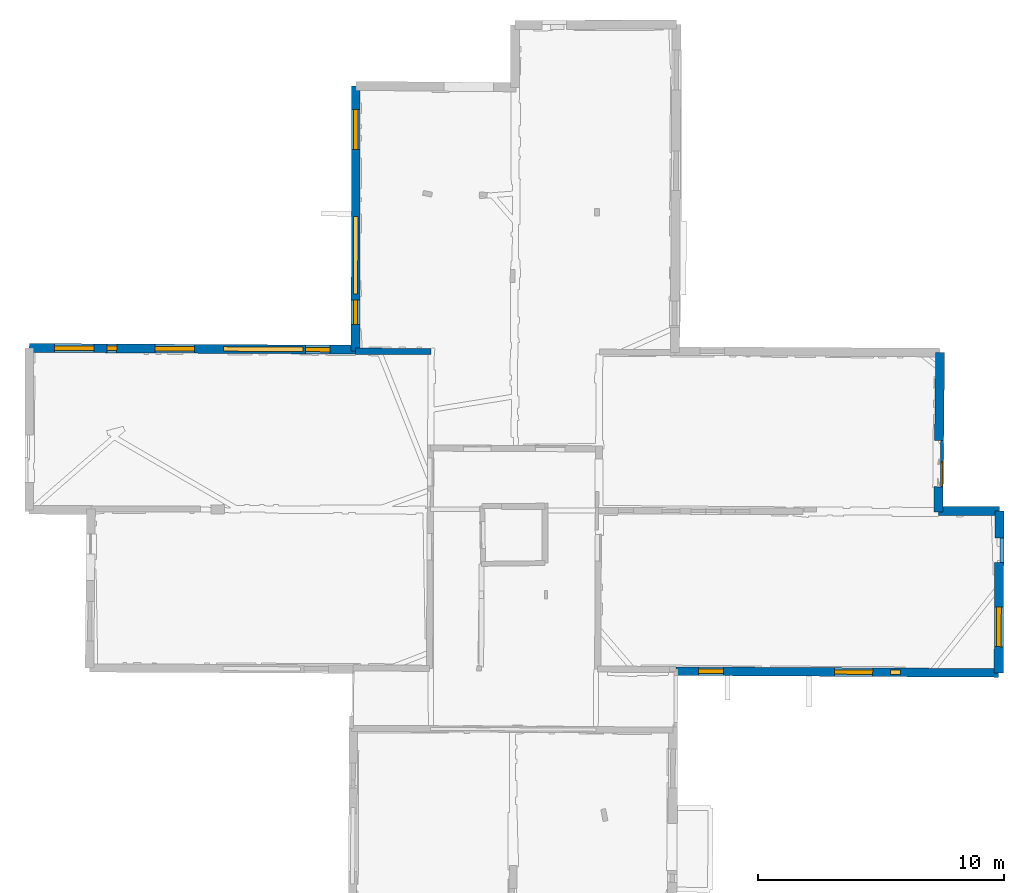
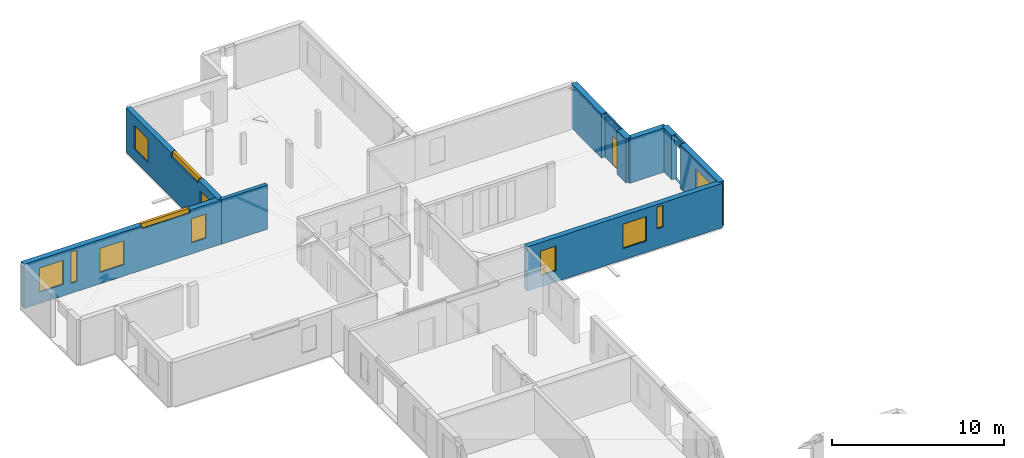
# One storey, part 8 of 14: 13 windows, 11 walls, 14 openings.
"""IFC2X3 building model written with IfcOpenShell, lengths in metres."""

from ifc_helpers import new_model, entity, si_unit, converted_unit, derived_unit, direction, frame, frame_2d, origin, origin_2d_with_axis, place, context, subcontext, project, spatial, polyline, rectangle, outline, extrude, source, transform, mapped, material, layer, layer_set, layer_usage, type_object, type_shapes, element, fill, save


model = new_model("IFC2X3")

# Units and contexts
model_context = context("Model", 3, precision=1e-05, world=origin(), true_north=direction((0.0, 1.0)))
body_context = subcontext(model_context, "Body", "Model", "MODEL_VIEW")
ifc_project = project(units=[si_unit("LENGTHUNIT", "METRE"), si_unit("AREAUNIT", "SQUARE_METRE"), si_unit("VOLUMEUNIT", "CUBIC_METRE"), converted_unit("PLANEANGLEUNIT", "DEGREE", entity("IfcRatioMeasure", 0.0174532925199433), si_unit("PLANEANGLEUNIT", "RADIAN"), dimensions=[0, 0, 0, 0, 0, 0, 0]), si_unit("MASSUNIT", "GRAM", prefix="KILO"), derived_unit("MASSDENSITYUNIT", [(si_unit("MASSUNIT", "GRAM", prefix="KILO"), 1), (si_unit("LENGTHUNIT", "METRE"), -3)]), derived_unit("MOMENTOFINERTIAUNIT", [(si_unit("LENGTHUNIT", "METRE"), 4)]), si_unit("TIMEUNIT", "SECOND"), si_unit("FREQUENCYUNIT", "HERTZ"), si_unit("THERMODYNAMICTEMPERATUREUNIT", "DEGREE_CELSIUS"), derived_unit("THERMALTRANSMITTANCEUNIT", [(si_unit("MASSUNIT", "GRAM", prefix="KILO"), 1), (si_unit("THERMODYNAMICTEMPERATUREUNIT", "KELVIN"), -1), (si_unit("TIMEUNIT", "SECOND"), -3)]), derived_unit("VOLUMETRICFLOWRATEUNIT", [(si_unit("LENGTHUNIT", "METRE"), 3), (si_unit("TIMEUNIT", "SECOND"), -1)]), si_unit("ELECTRICCURRENTUNIT", "AMPERE"), si_unit("ELECTRICVOLTAGEUNIT", "VOLT"), si_unit("POWERUNIT", "WATT"), si_unit("FORCEUNIT", "NEWTON", prefix="KILO"), si_unit("ILLUMINANCEUNIT", "LUX"), si_unit("LUMINOUSFLUXUNIT", "LUMEN"), si_unit("LUMINOUSINTENSITYUNIT", "CANDELA"), derived_unit("USERDEFINED", [(si_unit("MASSUNIT", "GRAM", prefix="KILO"), -1), (si_unit("LENGTHUNIT", "METRE"), -2), (si_unit("TIMEUNIT", "SECOND"), 3), (si_unit("LUMINOUSFLUXUNIT", "LUMEN"), 1)]), derived_unit("LINEARVELOCITYUNIT", [(si_unit("LENGTHUNIT", "METRE"), 1), (si_unit("TIMEUNIT", "SECOND"), -1)]), si_unit("PRESSUREUNIT", "PASCAL"), derived_unit("USERDEFINED", [(si_unit("LENGTHUNIT", "METRE"), -2), (si_unit("MASSUNIT", "GRAM", prefix="KILO"), 1), (si_unit("TIMEUNIT", "SECOND"), -2)]), derived_unit("LINEARFORCEUNIT", [(si_unit("MASSUNIT", "GRAM", prefix="KILO"), 1), (si_unit("LENGTHUNIT", "METRE"), 1), (si_unit("TIMEUNIT", "SECOND"), -2), (si_unit("LENGTHUNIT", "METRE"), -1)]), derived_unit("PLANARFORCEUNIT", [(si_unit("MASSUNIT", "GRAM", prefix="KILO"), 1), (si_unit("LENGTHUNIT", "METRE"), 1), (si_unit("TIMEUNIT", "SECOND"), -2), (si_unit("LENGTHUNIT", "METRE"), -2)])], contexts=[model_context])

# Site, building, storey
placement = place(None, origin())
site = spatial("IfcSite", under=ifc_project, at=placement, CompositionType="ELEMENT")
building = spatial("IfcBuilding", under=site, at=placement, CompositionType="ELEMENT")
storey_placement = place(placement, frame((0.0, 0.0, 8.83152770996094)))
storey = spatial("IfcBuildingStorey", under=building, at=storey_placement, Name="Level 4", CompositionType="ELEMENT", Elevation=8.83152770996094)

# Wall
ifc_material_1 = material(Name="Default wall")
ifc_layer_1 = layer(ifc_material_1, 0.25)
ifc_layer_set_1 = layer_set([ifc_layer_1], Name="wall_thickness_0.2500")
ifc_layer_usage_1 = layer_usage(ifc_layer_set_1, "AXIS2", "POSITIVE", -0.125)
wall_type_1 = type_object("IfcWallType", Name="wall_thickness_0.2500", PredefinedType="STANDARD", material=ifc_layer_set_1)
wall_1_placement = place(storey_placement, frame((-0.0725966707851251, 64.0874716307133, 0.0), z_axis=(0.0, 0.0, 1.0), x_axis=(0.999995007272062, -0.00315997325119514, 0.0)))
element("IfcWallStandardCase", 1, at=wall_1_placement, inside=storey, type_object=wall_type_1, material=ifc_layer_usage_1, Name="Wall:471", ObjectType="Wall", context=body_context, shape_type="SweptSolid", body=[
    extrude(outline(polyline([(3.07351311743161, -0.125), (3.07351311743161, 0.125), (0.0, 0.125), (0.0, -0.125), (3.07351311743161, -0.125)])), origin(), (0.0, 0.0, 1.0), 3.14668312072754),
])

# Wall, openings, windows
ifc_layer_2 = layer(ifc_material_1, 0.349999994039536)
ifc_layer_set_2 = layer_set([ifc_layer_2], Name="wall_thickness_0.3500")
ifc_layer_usage_2 = layer_usage(ifc_layer_set_2, "AXIS2", "POSITIVE", -0.174999997019768)
wall_type_2 = type_object("IfcWallType", Name="wall_thickness_0.3500", PredefinedType="STANDARD", material=ifc_layer_set_2)
wall_2_placement = place(storey_placement, frame((12.9328662606989, 51.1108377214405, 0.0), z_axis=(0.0, 0.0, 1.0), x_axis=(0.999983532806537, -0.00573882529414689, 0.0)))
wall_2 = element("IfcWallStandardCase", 2, at=wall_2_placement, inside=storey, type_object=wall_type_2, material=ifc_layer_usage_2, Name="Wall:474", ObjectType="Wall", context=body_context, shape_type="SweptSolid", body=[
    extrude(outline(polyline([(13.0916100065132, -0.174999997019768), (13.0916100065132, 0.174999997019768), (0.0, 0.174999997019768), (0.0, -0.174999997019768), (13.0916100065132, -0.174999997019768)])), origin(), (0.0, 0.0, 1.0), 3.14668312072754),
])
opening_1_placement = place(wall_2_placement, frame((8.6957989304469, -0.174999997019768, 1.41847229003906)))
opening_1 = element("IfcOpeningElement", 3, at=opening_1_placement, cuts=wall_2, Name="Opening : 415 x 1540 : 368", ObjectType="Opening", context=body_context, shape_type="SweptSolid", body=[
    extrude(rectangle(XDim=0.415, YDim=1.54, at=frame_2d((0.77, 0.2075), x_axis=(0.0, 1.0))), frame((0.0, 0.0, 0.0), z_axis=(0.0, 1.0, 0.0), x_axis=(0.0, 0.0, 1.0)), (0.0, 0.0, 1.0), 0.349999994039536),
])
opening_2_placement = place(wall_2_placement, frame((0.911729487264428, -0.174999997019768, 0.800472259521484)))
opening_2 = element("IfcOpeningElement", 4, at=opening_2_placement, cuts=wall_2, Name="Opening : 1010 x 1745 : 369", ObjectType="Opening", context=body_context, shape_type="SweptSolid", body=[
    extrude(rectangle(XDim=1.01, YDim=1.745, at=frame_2d((0.8725, 0.505), x_axis=(0.0, 1.0))), frame((0.0, 0.0, 0.0), z_axis=(0.0, 1.0, 0.0), x_axis=(0.0, 0.0, 1.0)), (0.0, 0.0, 1.0), 0.349999994039536),
])
opening_3_placement = place(wall_2_placement, frame((6.4217307997999, -0.174999997019768, 0.805472373962402)))
opening_3 = element("IfcOpeningElement", 5, at=opening_3_placement, cuts=wall_2, Name="Opening : 1560 x 1740 : 370", ObjectType="Opening", context=body_context, shape_type="SweptSolid", body=[
    extrude(rectangle(XDim=1.56, YDim=1.74, at=frame_2d((0.87, 0.78), x_axis=(0.0, 1.0))), frame((0.0, 0.0, 0.0), z_axis=(0.0, 1.0, 0.0), x_axis=(0.0, 0.0, 1.0)), (0.0, 0.0, 1.0), 0.349999994039536),
])
ifc_material_2 = material(Name="Window Default")
window_style_1 = type_object("IfcWindowStyle", Name="Window : 415 x 1540mm", ConstructionType="NOTDEFINED", OperationType="NOTDEFINED", ParameterTakesPrecedence=False, Sizeable=False, material=ifc_material_2)
shared_shape_1 = source(origin(), body_context, "Body", "SweptSolid", [
    extrude(rectangle(XDim=0.174999997019768, YDim=0.415, at=origin_2d_with_axis()), frame((0.2075, 0.174999997019768, 0.0), z_axis=(0.0, 0.0, 1.0), x_axis=(0.0, 1.0, 0.0)), (0.0, 0.0, 1.0), 1.54),
])
type_shapes(window_style_1, [shared_shape_1])
window_1_placement = place(opening_1_placement, origin())
window_1 = element("IfcWindow", 6, at=window_1_placement, inside=storey, type_object=window_style_1, Name="Window : 415 x 1540mm : 200", ObjectType="Window : 415 x 1540mm", OverallHeight=1.54, OverallWidth=0.415, context=body_context, shape_type="MappedRepresentation", body=[
    mapped(shared_shape_1, transform((0.0, 0.0, 0.0), scale=1.0)),
])
fill(opening_1, window_1)
window_style_2 = type_object("IfcWindowStyle", Name="Window : 1010 x 1745mm", ConstructionType="NOTDEFINED", OperationType="NOTDEFINED", ParameterTakesPrecedence=False, Sizeable=False, material=ifc_material_2)
shared_shape_2 = source(origin(), body_context, "Body", "SweptSolid", [
    extrude(rectangle(XDim=0.174999997019768, YDim=1.01, at=origin_2d_with_axis()), frame((0.505, 0.174999997019768, 0.0), z_axis=(0.0, 0.0, 1.0), x_axis=(0.0, 1.0, 0.0)), (0.0, 0.0, 1.0), 1.745),
])
type_shapes(window_style_2, [shared_shape_2])
window_2_placement = place(opening_2_placement, origin())
window_2 = element("IfcWindow", 7, at=window_2_placement, inside=storey, type_object=window_style_2, Name="Window : 1010 x 1745mm : 201", ObjectType="Window : 1010 x 1745mm", OverallHeight=1.745, OverallWidth=1.01, context=body_context, shape_type="MappedRepresentation", body=[
    mapped(shared_shape_2, transform((0.0, 0.0, 0.0), scale=1.0)),
])
fill(opening_2, window_2)
window_style_3 = type_object("IfcWindowStyle", Name="Window : 1560 x 1740mm", ConstructionType="NOTDEFINED", OperationType="NOTDEFINED", ParameterTakesPrecedence=False, Sizeable=False, material=ifc_material_2)
shared_shape_3 = source(origin(), body_context, "Body", "SweptSolid", [
    extrude(rectangle(XDim=0.174999997019768, YDim=1.56, at=origin_2d_with_axis()), frame((0.78, 0.174999997019768, 0.0), z_axis=(0.0, 0.0, 1.0), x_axis=(0.0, 1.0, 0.0)), (0.0, 0.0, 1.0), 1.74),
])
type_shapes(window_style_3, [shared_shape_3])
window_3_placement = place(opening_3_placement, origin())
window_3 = element("IfcWindow", 8, at=window_3_placement, inside=storey, type_object=window_style_3, Name="Window : 1560 x 1740mm : 202", ObjectType="Window : 1560 x 1740mm", OverallHeight=1.74, OverallWidth=1.56, context=body_context, shape_type="MappedRepresentation", body=[
    mapped(shared_shape_3, transform((0.0, 0.0, 0.0), scale=1.0)),
])
fill(opening_3, window_3)

wall_3_placement = place(storey_placement, frame((-0.0536861734466659, 74.854894371162, 0.0), z_axis=(0.0, 0.0, 1.0), x_axis=(-0.00175628624668275, -0.99999845772812, 0.0)))
wall_3 = element("IfcWallStandardCase", 9, at=wall_3_placement, inside=storey, type_object=wall_type_2, material=ifc_layer_usage_2, Name="Wall:477", ObjectType="Wall", context=body_context, shape_type="SweptSolid", body=[
    extrude(outline(polyline([(10.7674650316515, -0.174999997019768), (10.7674650316515, 0.174999997019768), (0.0, 0.174999997019768), (0.0, -0.174999997019768), (10.7674650316515, -0.174999997019768)])), origin(), (0.0, 0.0, 1.0), 3.14668312072754),
])
opening_4_placement = place(wall_3_placement, frame((5.29773766272082, -0.174999997019768, 2.88547229766846)))
opening_4 = element("IfcOpeningElement", 10, at=opening_4_placement, cuts=wall_3, Name="Opening : 3145 x 355 : 371", ObjectType="Opening", context=body_context, shape_type="SweptSolid", body=[
    extrude(rectangle(XDim=3.145, YDim=0.355, at=frame_2d((0.1775, 1.5725), x_axis=(0.0, 1.0))), frame((0.0, 0.0, 0.0), z_axis=(0.0, 1.0, 0.0), x_axis=(0.0, 0.0, 1.0)), (0.0, 0.0, 1.0), 0.349999994039536),
])
opening_5_placement = place(wall_3_placement, frame((0.960702470474783, -0.174999997019768, 0.800472259521484)))
opening_5 = element("IfcOpeningElement", 11, at=opening_5_placement, cuts=wall_3, Name="Opening : 1615 x 1700 : 372", ObjectType="Opening", context=body_context, shape_type="SweptSolid", body=[
    extrude(rectangle(XDim=1.615, YDim=1.7, at=frame_2d((0.85, 0.8075), x_axis=(0.0, 1.0))), frame((0.0, 0.0, 0.0), z_axis=(0.0, 1.0, 0.0), x_axis=(0.0, 0.0, 1.0)), (0.0, 0.0, 1.0), 0.349999994039536),
])
opening_6_placement = place(wall_3_placement, frame((8.68570522925139, -0.174999997019768, 0.800472259521484)))
opening_6 = element("IfcOpeningElement", 12, at=opening_6_placement, cuts=wall_3, Name="Opening : 1000 x 1715 : 373", ObjectType="Opening", context=body_context, shape_type="SweptSolid", body=[
    extrude(rectangle(XDim=1.0, YDim=1.715, at=frame_2d((0.8575, 0.5), x_axis=(0.0, 1.0))), frame((0.0, 0.0, 0.0), z_axis=(0.0, 1.0, 0.0), x_axis=(0.0, 0.0, 1.0)), (0.0, 0.0, 1.0), 0.349999994039536),
])
window_style_4 = type_object("IfcWindowStyle", Name="Window : 3145 x 355mm", ConstructionType="NOTDEFINED", OperationType="NOTDEFINED", ParameterTakesPrecedence=False, Sizeable=False, material=ifc_material_2)
shared_shape_4 = source(origin(), body_context, "Body", "SweptSolid", [
    extrude(rectangle(XDim=0.174999997019768, YDim=3.145, at=origin_2d_with_axis()), frame((1.5725, 0.174999997019768, 0.0), z_axis=(0.0, 0.0, 1.0), x_axis=(0.0, 1.0, 0.0)), (0.0, 0.0, 1.0), 0.355),
])
type_shapes(window_style_4, [shared_shape_4])
window_4_placement = place(opening_4_placement, origin())
window_4 = element("IfcWindow", 13, at=window_4_placement, inside=storey, type_object=window_style_4, Name="Window : 3145 x 355mm : 203", ObjectType="Window : 3145 x 355mm", OverallHeight=0.355, OverallWidth=3.145, context=body_context, shape_type="MappedRepresentation", body=[
    mapped(shared_shape_4, transform((0.0, 0.0, 0.0), scale=1.0)),
])
fill(opening_4, window_4)
window_style_5 = type_object("IfcWindowStyle", Name="Window : 1615 x 1700mm", ConstructionType="NOTDEFINED", OperationType="NOTDEFINED", ParameterTakesPrecedence=False, Sizeable=False, material=ifc_material_2)
shared_shape_5 = source(origin(), body_context, "Body", "SweptSolid", [
    extrude(rectangle(XDim=0.174999997019768, YDim=1.615, at=origin_2d_with_axis()), frame((0.8075, 0.174999997019768, 0.0), z_axis=(0.0, 0.0, 1.0), x_axis=(0.0, 1.0, 0.0)), (0.0, 0.0, 1.0), 1.7),
])
type_shapes(window_style_5, [shared_shape_5])
window_5_placement = place(opening_5_placement, origin())
window_5 = element("IfcWindow", 14, at=window_5_placement, inside=storey, type_object=window_style_5, Name="Window : 1615 x 1700mm : 204", ObjectType="Window : 1615 x 1700mm", OverallHeight=1.7, OverallWidth=1.615, context=body_context, shape_type="MappedRepresentation", body=[
    mapped(shared_shape_5, transform((0.0, 0.0, 0.0), scale=1.0)),
])
fill(opening_5, window_5)
window_style_6 = type_object("IfcWindowStyle", Name="Window : 1000 x 1715mm", ConstructionType="NOTDEFINED", OperationType="NOTDEFINED", ParameterTakesPrecedence=False, Sizeable=False, material=ifc_material_2)
shared_shape_6 = source(origin(), body_context, "Body", "SweptSolid", [
    extrude(rectangle(XDim=0.174999997019768, YDim=1.0, at=origin_2d_with_axis()), frame((0.5, 0.174999997019768, 0.0), z_axis=(0.0, 0.0, 1.0), x_axis=(0.0, 1.0, 0.0)), (0.0, 0.0, 1.0), 1.715),
])
type_shapes(window_style_6, [shared_shape_6])
window_6_placement = place(opening_6_placement, origin())
window_6 = element("IfcWindow", 15, at=window_6_placement, inside=storey, type_object=window_style_6, Name="Window : 1000 x 1715mm : 205", ObjectType="Window : 1000 x 1715mm", OverallHeight=1.715, OverallWidth=1.0, context=body_context, shape_type="MappedRepresentation", body=[
    mapped(shared_shape_6, transform((0.0, 0.0, 0.0), scale=1.0)),
])
fill(opening_6, window_6)

# Wall, opening, window
ifc_layer_3 = layer(ifc_material_1, 0.119999997317791)
ifc_layer_set_3 = layer_set([ifc_layer_3], Name="wall_thickness_0.1200")
ifc_layer_usage_3 = layer_usage(ifc_layer_set_3, "AXIS2", "POSITIVE", -0.0599999986588955)
wall_type_3 = type_object("IfcWallType", Name="wall_thickness_0.1200", PredefinedType="STANDARD", material=ifc_layer_set_3)
wall_4_placement = place(storey_placement, frame((23.7334984998633, 60.4629093633367, 0.0), z_axis=(0.0, 0.0, 1.0), x_axis=(-0.0107502948328972, -0.999942213910887, 0.0)))
wall_4 = element("IfcWallStandardCase", 16, at=wall_4_placement, inside=storey, type_object=wall_type_3, material=ifc_layer_usage_3, Name="Wall:486", ObjectType="Wall", context=body_context, shape_type="SweptSolid", body=[
    extrude(outline(polyline([(1.87500535240021, -0.0599999986588955), (1.87500535240021, 0.0599999986588955), (0.0, 0.0599999986588955), (0.0, -0.0599999986588955), (1.87500535240021, -0.0599999986588955)])), origin(), (0.0, 0.0, 1.0), 3.14668312072754),
])
opening_7_placement = place(wall_4_placement, frame((0.849967488055786, -0.0599999986588955, 0.0354728698730469)))
opening_7 = element("IfcOpeningElement", 17, at=opening_7_placement, cuts=wall_4, Name="Opening : 1020 x 1985 : 378", ObjectType="Opening", context=body_context, shape_type="SweptSolid", body=[
    extrude(rectangle(XDim=1.02, YDim=1.985, at=frame_2d((0.9925, 0.51), x_axis=(0.0, 1.0))), frame((0.0, 0.0, 0.0), z_axis=(0.0, 1.0, 0.0), x_axis=(0.0, 0.0, 1.0)), (0.0, 0.0, 1.0), 0.119999997317791),
])
window_style_7 = type_object("IfcWindowStyle", Name="Window : 1020 x 1985mm", ConstructionType="NOTDEFINED", OperationType="NOTDEFINED", ParameterTakesPrecedence=False, Sizeable=False, material=ifc_material_2)
shared_shape_7 = source(origin(), body_context, "Body", "SweptSolid", [
    extrude(rectangle(XDim=0.0599999986588955, YDim=1.02, at=origin_2d_with_axis()), frame((0.51, 0.0599999986588955, 0.0), z_axis=(0.0, 0.0, 1.0), x_axis=(0.0, 1.0, 0.0)), (0.0, 0.0, 1.0), 1.985),
])
type_shapes(window_style_7, [shared_shape_7])
window_7_placement = place(opening_7_placement, origin())
window_7 = element("IfcWindow", 18, at=window_7_placement, inside=storey, type_object=window_style_7, Name="Window : 1020 x 1985mm : 206", ObjectType="Window : 1020 x 1985mm", OverallHeight=1.985, OverallWidth=1.02, context=body_context, shape_type="MappedRepresentation", body=[
    mapped(shared_shape_7, transform((0.0, 0.0, 0.0), scale=1.0)),
])
fill(opening_7, window_7)

# Wall
ifc_layer_4 = layer(ifc_material_1, 0.370000004768372)
ifc_layer_set_4 = layer_set([ifc_layer_4], Name="wall_thickness_0.3700")
ifc_layer_usage_4 = layer_usage(ifc_layer_set_4, "AXIS2", "POSITIVE", -0.185000002384186)
wall_type_4 = type_object("IfcWallType", Name="wall_thickness_0.3700", PredefinedType="STANDARD", material=ifc_layer_set_4)
wall_5_placement = place(storey_placement, frame((26.0541624507356, 57.607519848895, 0.0), z_axis=(0.0, 0.0, 1.0), x_axis=(-0.00454995237997201, -0.999989648913097, 0.0)))
element("IfcWallStandardCase", 19, at=wall_5_placement, inside=storey, type_object=wall_type_4, material=ifc_layer_usage_4, Name="Wall:401", ObjectType="Wall", context=body_context, shape_type="SweptSolid", body=[
    extrude(outline(polyline([(1.09495533422196, -0.185000002384186), (1.09495533422196, 0.185000002384186), (0.0, 0.185000002384186), (0.0, -0.185000002384186), (1.09495533422196, -0.185000002384186)])), origin(), (0.0, 0.0, 1.0), 3.14668312072754),
])

# Wall, opening, window
wall_6_placement = place(storey_placement, frame((26.0446257065105, 55.5126023183358, 0.0), z_axis=(0.0, 0.0, 1.0), x_axis=(-0.00454923798231252, -0.999989652163351, 0.0)))
wall_6 = element("IfcWallStandardCase", 20, at=wall_6_placement, inside=storey, type_object=wall_type_4, material=ifc_layer_usage_4, Name="Wall:402", ObjectType="Wall", context=body_context, shape_type="SweptSolid", body=[
    extrude(outline(polyline([(4.47694070531321, -0.185000002384186), (4.47694070531321, 0.185000002384186), (0.0, 0.185000002384186), (0.0, -0.185000002384186), (4.47694070531321, -0.185000002384186)])), origin(), (0.0, 0.0, 1.0), 3.14668312072754),
])
opening_8_placement = place(wall_6_placement, frame((1.80821573201221, -0.185000002384186, 0.805472373962402)))
opening_8 = element("IfcOpeningElement", 21, at=opening_8_placement, cuts=wall_6, Name="Opening : 1605 x 1695 : 323", ObjectType="Opening", context=body_context, shape_type="SweptSolid", body=[
    extrude(rectangle(XDim=1.605, YDim=1.695, at=frame_2d((0.8475, 0.8025), x_axis=(0.0, 1.0))), frame((0.0, 0.0, 0.0), z_axis=(0.0, 1.0, 0.0), x_axis=(0.0, 0.0, 1.0)), (0.0, 0.0, 1.0), 0.370000004768372),
])
window_style_8 = type_object("IfcWindowStyle", Name="Window : 1605 x 1695mm", ConstructionType="NOTDEFINED", OperationType="NOTDEFINED", ParameterTakesPrecedence=False, Sizeable=False, material=ifc_material_2)
shared_shape_8 = source(origin(), body_context, "Body", "SweptSolid", [
    extrude(rectangle(XDim=0.185000002384186, YDim=1.605, at=origin_2d_with_axis()), frame((0.8025, 0.185000002384186, 0.0), z_axis=(0.0, 0.0, 1.0), x_axis=(0.0, 1.0, 0.0)), (0.0, 0.0, 1.0), 1.695),
])
type_shapes(window_style_8, [shared_shape_8])
window_8_placement = place(opening_8_placement, origin())
window_8 = element("IfcWindow", 22, at=window_8_placement, inside=storey, type_object=window_style_8, Name="Window : 1605 x 1695mm : 174", ObjectType="Window : 1605 x 1695mm", OverallHeight=1.695, OverallWidth=1.605, context=body_context, shape_type="MappedRepresentation", body=[
    mapped(shared_shape_8, transform((0.0, 0.0, 0.0), scale=1.0)),
])
fill(opening_8, window_8)

# Walls
wall_7_placement = place(storey_placement, frame((23.6468136752284, 64.0337838540516, 0.0), z_axis=(0.0, 0.0, 1.0), x_axis=(-0.0110572017912558, -0.999938867275669, 0.0)))
element("IfcWallStandardCase", 23, at=wall_7_placement, inside=storey, type_object=wall_type_4, material=ifc_layer_usage_4, Name="Wall:408", ObjectType="Wall", context=body_context, shape_type="SweptSolid", body=[
    extrude(outline(polyline([(3.56968004677602, -0.185000002384186), (3.56968004677602, 0.185000002384186), (0.0, 0.185000002384186), (0.0, -0.185000002384186), (3.56968004677602, -0.185000002384186)])), origin(), (0.0, 0.0, 1.0), 3.14668312072754),
])
wall_8_placement = place(storey_placement, frame((23.5866101250468, 58.5894328444568, 0.0), z_axis=(0.0, 0.0, 1.0), x_axis=(-0.0110569858478835, -0.999938869663521, 0.0)))
element("IfcWallStandardCase", 24, at=wall_8_placement, inside=storey, type_object=wall_type_4, material=ifc_layer_usage_4, Name="Wall:409", ObjectType="Wall", context=body_context, shape_type="SweptSolid", body=[
    extrude(outline(polyline([(1.02224495477766, -0.185000002384186), (1.02224495477766, 0.185000002384186), (0.0, 0.185000002384186), (0.0, -0.185000002384186), (1.02224495477766, -0.185000002384186)])), origin(), (0.0, 0.0, 1.0), 3.14668312072754),
])
ifc_layer_5 = layer(ifc_material_1, 0.360000014305115)
ifc_layer_set_5 = layer_set([ifc_layer_5], Name="wall_thickness_0.3600")
ifc_layer_usage_5 = layer_usage(ifc_layer_set_5, "AXIS2", "POSITIVE", -0.180000007152557)
wall_type_5 = type_object("IfcWallType", Name="wall_thickness_0.3600", PredefinedType="STANDARD", material=ifc_layer_set_5)
wall_9_placement = place(storey_placement, frame((23.575710408771, 57.6039166560691, 0.0), z_axis=(0.0, 0.0, 1.0), x_axis=(0.999998942225334, 0.00145449242455361, 0.0)))
element("IfcWallStandardCase", 25, at=wall_9_placement, inside=storey, type_object=wall_type_5, material=ifc_layer_usage_5, Name="Wall:497", ObjectType="Wall", context=body_context, shape_type="SweptSolid", body=[
    extrude(outline(polyline([(2.47845148944105, -0.180000007152557), (2.47845148944105, 0.180000007152557), (0.0, 0.180000007152557), (0.0, -0.180000007152557), (2.47845148944105, -0.180000007152557)])), origin(), (0.0, 0.0, 1.0), 3.14668312072754),
])

# Wall, openings, windows
wall_10_placement = place(storey_placement, frame((-13.305897288311, 64.2230024712479, 0.0), z_axis=(0.0, 0.0, 1.0), x_axis=(0.999985552208707, -0.00537544173512645, 0.0)))
wall_10 = element("IfcWallStandardCase", 26, at=wall_10_placement, inside=storey, type_object=wall_type_5, material=ifc_layer_usage_5, Name="Wall:502", ObjectType="Wall", context=body_context, shape_type="SweptSolid", body=[
    extrude(outline(polyline([(13.2336053694947, -0.180000007152557), (13.2336053694947, 0.180000007152557), (0.0, 0.180000007152557), (0.0, -0.180000007152557), (13.2336053694947, -0.180000007152557)])), origin(), (0.0, 0.0, 1.0), 3.14668312072754),
])
opening_9_placement = place(wall_10_placement, frame((3.14552846936702, -0.180000007152557, 0.699471473693848)))
opening_9 = element("IfcOpeningElement", 27, at=opening_9_placement, cuts=wall_10, Name="Opening : 405 x 2235 : 397", ObjectType="Opening", context=body_context, shape_type="SweptSolid", body=[
    extrude(rectangle(XDim=0.405, YDim=2.235, at=frame_2d((1.1175, 0.2025), x_axis=(0.0, 1.0))), frame((0.0, 0.0, 0.0), z_axis=(0.0, 1.0, 0.0), x_axis=(0.0, 0.0, 1.0)), (0.0, 0.0, 1.0), 0.360000014305115),
])
opening_10_placement = place(wall_10_placement, frame((1.03242267636601, -0.180000007152557, 0.81047248840332)))
opening_10 = element("IfcOpeningElement", 28, at=opening_10_placement, cuts=wall_10, Name="Opening : 1595 x 1720 : 398", ObjectType="Opening", context=body_context, shape_type="SweptSolid", body=[
    extrude(rectangle(XDim=1.595, YDim=1.72, at=frame_2d((0.86, 0.7975), x_axis=(0.0, 1.0))), frame((0.0, 0.0, 0.0), z_axis=(0.0, 1.0, 0.0), x_axis=(0.0, 0.0, 1.0)), (0.0, 0.0, 1.0), 0.360000014305115),
])
opening_11_placement = place(wall_10_placement, frame((5.10242392863749, -0.180000007152557, 0.800472259521484)))
opening_11 = element("IfcOpeningElement", 29, at=opening_11_placement, cuts=wall_10, Name="Opening : 1605 x 1715 : 399", ObjectType="Opening", context=body_context, shape_type="SweptSolid", body=[
    extrude(rectangle(XDim=1.605, YDim=1.715, at=frame_2d((0.8575, 0.8025), x_axis=(0.0, 1.0))), frame((0.0, 0.0, 0.0), z_axis=(0.0, 1.0, 0.0), x_axis=(0.0, 0.0, 1.0)), (0.0, 0.0, 1.0), 0.360000014305115),
])
opening_12_placement = place(wall_10_placement, frame((7.88742347267984, -0.180000007152557, 2.92547225952148)))
opening_12 = element("IfcOpeningElement", 30, at=opening_12_placement, cuts=wall_10, Name="Opening : 3215 x 315 : 400", ObjectType="Opening", context=body_context, shape_type="SweptSolid", body=[
    extrude(rectangle(XDim=3.215, YDim=0.315, at=frame_2d((0.1575, 1.6075), x_axis=(0.0, 1.0))), frame((0.0, 0.0, 0.0), z_axis=(0.0, 1.0, 0.0), x_axis=(0.0, 0.0, 1.0)), (0.0, 0.0, 1.0), 0.360000014305115),
])
opening_13_placement = place(wall_10_placement, frame((11.2024242318252, -0.180000007152557, 0.78547191619873)))
opening_13 = element("IfcOpeningElement", 31, at=opening_13_placement, cuts=wall_10, Name="Opening : 990 x 1715 : 401", ObjectType="Opening", context=body_context, shape_type="SweptSolid", body=[
    extrude(rectangle(XDim=0.99, YDim=1.715, at=frame_2d((0.8575, 0.495), x_axis=(0.0, 1.0))), frame((0.0, 0.0, 0.0), z_axis=(0.0, 1.0, 0.0), x_axis=(0.0, 0.0, 1.0)), (0.0, 0.0, 1.0), 0.360000014305115),
])
window_style_9 = type_object("IfcWindowStyle", Name="Window : 990 x 1715mm", ConstructionType="NOTDEFINED", OperationType="NOTDEFINED", ParameterTakesPrecedence=False, Sizeable=False, material=ifc_material_2)
shared_shape_9 = source(origin(), body_context, "Body", "SweptSolid", [
    extrude(rectangle(XDim=0.174999997019768, YDim=0.99, at=origin_2d_with_axis()), frame((0.495, 0.174999997019768, 0.0), z_axis=(0.0, 0.0, 1.0), x_axis=(0.0, 1.0, 0.0)), (0.0, 0.0, 1.0), 1.715),
])
type_shapes(window_style_9, [shared_shape_9])
window_9_placement = place(opening_13_placement, origin())
window_9 = element("IfcWindow", 32, at=window_9_placement, inside=storey, type_object=window_style_9, Name="Window : 990 x 1715mm : 224", ObjectType="Window : 990 x 1715mm", OverallHeight=1.715, OverallWidth=0.99, context=body_context, shape_type="MappedRepresentation", body=[
    mapped(shared_shape_9, transform((0.0, 0.0, 0.0), scale=1.0)),
])
fill(opening_13, window_9)
window_style_10 = type_object("IfcWindowStyle", Name="Window : 405 x 2235mm", ConstructionType="NOTDEFINED", OperationType="NOTDEFINED", ParameterTakesPrecedence=False, Sizeable=False, material=ifc_material_2)
shared_shape_10 = source(origin(), body_context, "Body", "SweptSolid", [
    extrude(rectangle(XDim=0.180000007152557, YDim=0.405, at=origin_2d_with_axis()), frame((0.2025, 0.180000007152557, 0.0), z_axis=(0.0, 0.0, 1.0), x_axis=(0.0, 1.0, 0.0)), (0.0, 0.0, 1.0), 2.235),
])
type_shapes(window_style_10, [shared_shape_10])
window_10_placement = place(opening_9_placement, origin())
window_10 = element("IfcWindow", 33, at=window_10_placement, inside=storey, type_object=window_style_10, Name="Window : 405 x 2235mm : 220", ObjectType="Window : 405 x 2235mm", OverallHeight=2.235, OverallWidth=0.405, context=body_context, shape_type="MappedRepresentation", body=[
    mapped(shared_shape_10, transform((0.0, 0.0, 0.0), scale=1.0)),
])
fill(opening_9, window_10)
window_style_11 = type_object("IfcWindowStyle", Name="Window : 1595 x 1720mm", ConstructionType="NOTDEFINED", OperationType="NOTDEFINED", ParameterTakesPrecedence=False, Sizeable=False, material=ifc_material_2)
shared_shape_11 = source(origin(), body_context, "Body", "SweptSolid", [
    extrude(rectangle(XDim=0.180000007152557, YDim=1.595, at=origin_2d_with_axis()), frame((0.7975, 0.180000007152557, 0.0), z_axis=(0.0, 0.0, 1.0), x_axis=(0.0, 1.0, 0.0)), (0.0, 0.0, 1.0), 1.72),
])
type_shapes(window_style_11, [shared_shape_11])
window_11_placement = place(opening_10_placement, origin())
window_11 = element("IfcWindow", 34, at=window_11_placement, inside=storey, type_object=window_style_11, Name="Window : 1595 x 1720mm : 221", ObjectType="Window : 1595 x 1720mm", OverallHeight=1.72, OverallWidth=1.595, context=body_context, shape_type="MappedRepresentation", body=[
    mapped(shared_shape_11, transform((0.0, 0.0, 0.0), scale=1.0)),
])
fill(opening_10, window_11)
window_style_12 = type_object("IfcWindowStyle", Name="Window : 1605 x 1715mm", ConstructionType="NOTDEFINED", OperationType="NOTDEFINED", ParameterTakesPrecedence=False, Sizeable=False, material=ifc_material_2)
shared_shape_12 = source(origin(), body_context, "Body", "SweptSolid", [
    extrude(rectangle(XDim=0.180000007152557, YDim=1.605, at=origin_2d_with_axis()), frame((0.8025, 0.180000007152557, 0.0), z_axis=(0.0, 0.0, 1.0), x_axis=(0.0, 1.0, 0.0)), (0.0, 0.0, 1.0), 1.715),
])
type_shapes(window_style_12, [shared_shape_12])
window_12_placement = place(opening_11_placement, origin())
window_12 = element("IfcWindow", 35, at=window_12_placement, inside=storey, type_object=window_style_12, Name="Window : 1605 x 1715mm : 222", ObjectType="Window : 1605 x 1715mm", OverallHeight=1.715, OverallWidth=1.605, context=body_context, shape_type="MappedRepresentation", body=[
    mapped(shared_shape_12, transform((0.0, 0.0, 0.0), scale=1.0)),
])
fill(opening_11, window_12)
window_style_13 = type_object("IfcWindowStyle", Name="Window : 3215 x 315mm", ConstructionType="NOTDEFINED", OperationType="NOTDEFINED", ParameterTakesPrecedence=False, Sizeable=False, material=ifc_material_2)
shared_shape_13 = source(origin(), body_context, "Body", "SweptSolid", [
    extrude(rectangle(XDim=0.180000007152557, YDim=3.215, at=origin_2d_with_axis()), frame((1.6075, 0.180000007152557, 0.0), z_axis=(0.0, 0.0, 1.0), x_axis=(0.0, 1.0, 0.0)), (0.0, 0.0, 1.0), 0.315),
])
type_shapes(window_style_13, [shared_shape_13])
window_13_placement = place(opening_12_placement, origin())
window_13 = element("IfcWindow", 36, at=window_13_placement, inside=storey, type_object=window_style_13, Name="Window : 3215 x 315mm : 223", ObjectType="Window : 3215 x 315mm", OverallHeight=0.315, OverallWidth=3.215, context=body_context, shape_type="MappedRepresentation", body=[
    mapped(shared_shape_13, transform((0.0, 0.0, 0.0), scale=1.0)),
])
fill(opening_12, window_13)

# Wall, opening
ifc_layer_6 = layer(ifc_material_1, 0.170000001788139)
ifc_layer_set_6 = layer_set([ifc_layer_6], Name="wall_thickness_0.1700")
ifc_layer_usage_6 = layer_usage(ifc_layer_set_6, "AXIS2", "POSITIVE", -0.0850000008940697)
wall_type_6 = type_object("IfcWallType", Name="wall_thickness_0.1700", PredefinedType="STANDARD", material=ifc_layer_set_6)
wall_11_placement = place(storey_placement, frame((26.1530140867408, 56.51163965219, 0.0), z_axis=(0.0, 0.0, 1.0), x_axis=(0.00118068401240632, -0.999999302992389, 0.0)))
wall_11 = element("IfcWallStandardCase", 37, at=wall_11_placement, inside=storey, type_object=wall_type_6, material=ifc_layer_usage_6, Name="Wall:429", ObjectType="Wall", context=body_context, shape_type="SweptSolid", body=[
    extrude(outline(polyline([(0.999970179408701, -0.0850000008940697), (0.999970179408701, 0.0850000008940697), (0.0, 0.0850000008940697), (0.0, -0.0850000008940697), (0.999970179408701, -0.0850000008940697)])), origin(), (0.0, 0.0, 1.0), 3.14668312072754),
])
opening_14_placement = place(wall_11_placement, frame((-0.081798774232162, -0.0850000008940697, 0.00547218322753906)))
element("IfcOpeningElement", 38, at=opening_14_placement, cuts=wall_11, Name="Opening : 1970 x 2495 : 335", ObjectType="Opening", context=body_context, shape_type="SweptSolid", body=[
    extrude(rectangle(XDim=1.97, YDim=2.495, at=frame_2d((1.2475, 0.985), x_axis=(0.0, 1.0))), frame((0.0, 0.0, 0.0), z_axis=(0.0, 1.0, 0.0), x_axis=(0.0, 0.0, 1.0)), (0.0, 0.0, 1.0), 0.170000001788139),
])

save(model, "model.ifc")
